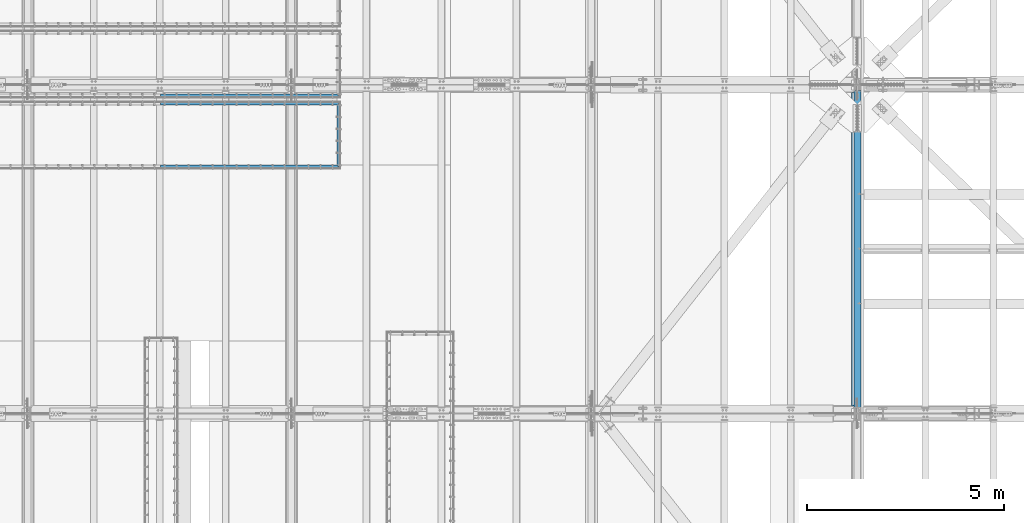
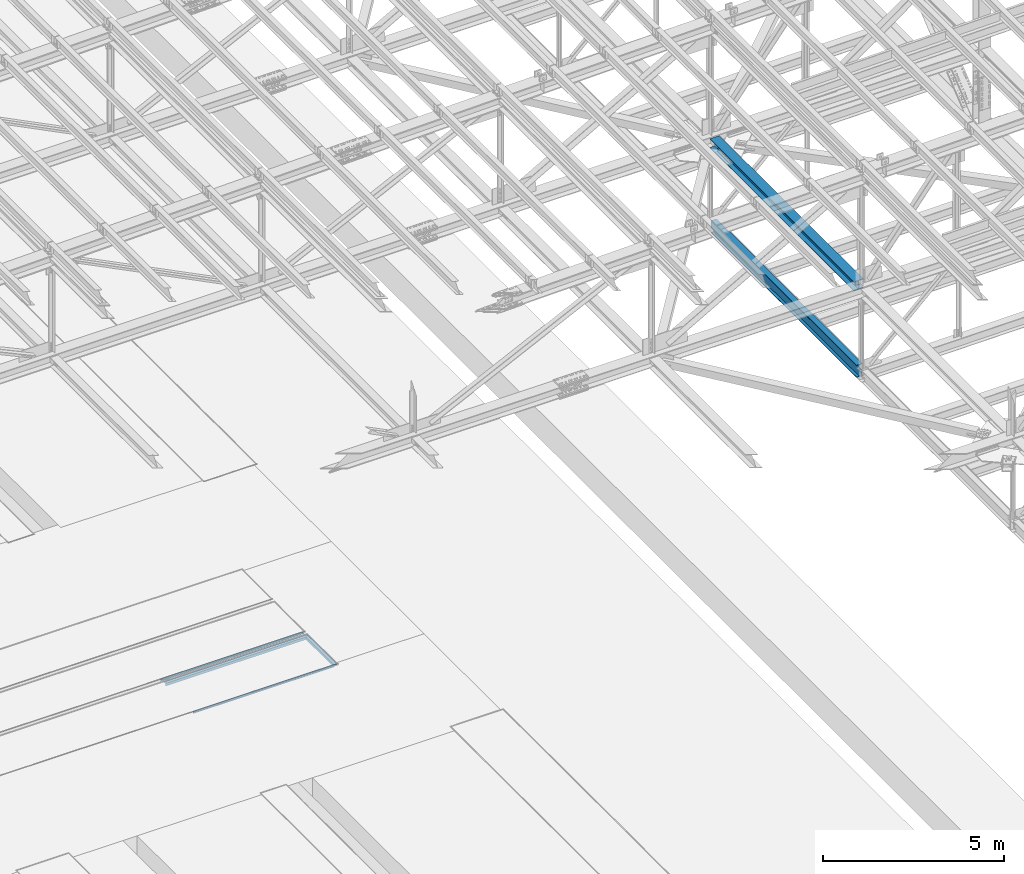
# One storey, part 1857 of 3843: 6 beams, 6 elements without a shape of their own.
"""IFC2X3 building model written with IfcOpenShell, lengths in millimetres."""

from ifc_helpers import new_model, si_unit, frame, origin_with_axes, place, context, subcontext, project, spatial, faceted_brep, material, type_object, element, aggregate, save


model = new_model("IFC2X3")

# Units and contexts
model_context = context("Model", 3, precision=1e-05, world=origin_with_axes())
body_context = subcontext(model_context, "Body", "Model", "MODEL_VIEW")
ifc_project = project(units=[si_unit("LENGTHUNIT", "METRE", prefix="MILLI"), si_unit("AREAUNIT", "SQUARE_METRE"), si_unit("VOLUMEUNIT", "CUBIC_METRE"), si_unit("MASSUNIT", "GRAM", prefix="KILO"), si_unit("TIMEUNIT", "SECOND"), si_unit("PLANEANGLEUNIT", "RADIAN"), si_unit("SOLIDANGLEUNIT", "STERADIAN"), si_unit("THERMODYNAMICTEMPERATUREUNIT", "DEGREE_CELSIUS"), si_unit("LUMINOUSINTENSITYUNIT", "LUMEN")], contexts=[model_context])

# Site, building, storey
site_placement = place(None, origin_with_axes())
site = spatial("IfcSite", under=ifc_project, at=site_placement, CompositionType="ELEMENT")
building_placement = place(site_placement, origin_with_axes())
building = spatial("IfcBuilding", under=site, at=building_placement, Name="Undefined", CompositionType="ELEMENT")
storey_placement = place(building_placement, origin_with_axes())
storey = spatial("IfcBuildingStorey", under=building, at=storey_placement, Name="Undefined", CompositionType="ELEMENT", Elevation=0.0)

# Assembly, beam
assembly_1_placement = place(storey_placement, origin_with_axes())
assembly_1 = element("IfcElementAssembly", 1, at=assembly_1_placement, inside=storey, Name="EMBED_ANGLE", AssemblyPlace="NOTDEFINED", PredefinedType="RIGID_FRAME")
ifc_material_1 = material(Name="STEEL/A36")
beam_type_1 = type_object("IfcBeamType", Name="L3-1/2X3-1/2X5/16", PredefinedType="NOTDEFINED")
beam_1_placement = place(assembly_1_placement, frame((63875.412, 58632.3439999965, 30410.15), z_axis=(0.0, 0.0, -1.0), x_axis=(-1.0, 0.0, 0.0)))
beam_1 = element("IfcBeam", 2, at=beam_1_placement, type_object=beam_type_1, material=ifc_material_1, Name="EMBED_ANGLE", ObjectType="L3-1/2X3-1/2X5/16", context=body_context, shape_type="Brep", body=[
    faceted_brep([(88.8999999971129, 44.4500000000007, -44.4499999999971), (88.8999999965163, 44.4499999999971, 44.4500000000007), (4571.99999999999, 44.4499999999971, 44.4500000000007), (4571.99999999999, 44.4499999999971, -44.4500000000007), (80.9624999965163, 36.5124999999971, 44.4500000000007), (4571.99999999999, 36.5124999999971, 44.4500000000007), (80.9624999971129, 36.5125000000007, -36.5124999999971), (4571.99999999999, 36.5124999999971, -36.5125000000007), (3.63797880709171e-12, -44.4499999999971, -36.5125000000007), (4571.99999999999, -44.4499999999971, -36.5125000000007), (3.63797880709171e-12, -44.4499999999971, -44.4500000000007), (4571.99999999999, -44.4499999999971, -44.4500000000007)], [[[0, 1, 2, 3]], [[1, 4, 5, 2]], [[4, 6, 7, 5]], [[6, 8, 9, 7]], [[8, 10, 11, 9]], [[10, 0, 3, 11]], [[5, 7, 9, 11, 3, 2]], [[10, 8, 6, 4, 1, 0]]]),
])
aggregate(assembly_1, [beam_1])

assembly_2_placement = place(storey_placement, origin_with_axes())
assembly_2 = element("IfcElementAssembly", 3, at=assembly_2_placement, inside=storey, Name="EMBED_ANGLE", AssemblyPlace="NOTDEFINED", PredefinedType="RIGID_FRAME")
beam_2_placement = place(assembly_2_placement, frame((63830.9615883789, 56784.8750000029, 30410.15), z_axis=(1.0, 0.0, 0.0), x_axis=(0.0, 1.0, 0.0)))
beam_2 = element("IfcBeam", 4, at=beam_2_placement, type_object=beam_type_1, material=ifc_material_1, Name="EMBED_ANGLE", ObjectType="L3-1/2X3-1/2X5/16", context=body_context, shape_type="Brep", body=[
    faceted_brep([(88.8999999971129, 44.4500000000007, -44.4499999999971), (-3.63797880709171e-12, 44.4499999999971, 44.4500000000007), (1702.18099999712, 44.4500000000007, 44.4499999999971), (1613.28099999713, 44.4500000000007, -44.4499999999971), (-3.63797880709171e-12, 36.5124999999971, 44.4500000000007), (1702.18099999712, 36.5125000000007, 44.4499999999971), (80.9624999971129, 36.5125000000007, -36.5124999999971), (1621.21849999713, 36.5125000000007, -36.5124999999971), (80.9624999971129, -44.4500000000007, -36.5124999999971), (1621.21849999713, -44.4500000000007, -36.5124999999971), (88.8999999971129, -44.4500000000007, -44.4499999999971), (1613.28099999713, -44.4500000000007, -44.4499999999971)], [[[0, 1, 2, 3]], [[1, 4, 5, 2]], [[4, 6, 7, 5]], [[6, 8, 9, 7]], [[8, 10, 11, 9]], [[10, 0, 3, 11]], [[5, 7, 9, 11, 3, 2]], [[10, 8, 6, 4, 1, 0]]]),
])
aggregate(assembly_2, [beam_2])

assembly_3_placement = place(storey_placement, origin_with_axes())
assembly_3 = element("IfcElementAssembly", 5, at=assembly_3_placement, inside=storey, Name="EMBED_ANGLE", AssemblyPlace="NOTDEFINED", PredefinedType="RIGID_FRAME")
beam_3_placement = place(assembly_3_placement, frame((63875.4115883789, 56829.325, 30410.15), z_axis=(0.0, 0.0, -1.0), x_axis=(-1.0, 0.0, 0.0)))
beam_3 = element("IfcBeam", 6, at=beam_3_placement, type_object=beam_type_1, material=ifc_material_1, Name="EMBED_ANGLE", ObjectType="L3-1/2X3-1/2X5/16", context=body_context, shape_type="Brep", body=[
    faceted_brep([(88.8999999971129, 44.4500000000007, -44.4499999999971), (88.8999999965163, 44.4499999999971, 44.4500000000007), (4571.99999999999, 44.4499999999971, 44.4500000000007), (4571.99999999999, 44.4499999999971, -44.4500000000007), (80.9624999965163, 36.5124999999971, 44.4500000000007), (4571.99999999999, 36.5124999999971, 44.4500000000007), (80.9624999971129, 36.5125000000007, -36.5124999999971), (4571.99999999999, 36.5124999999971, -36.5125000000007), (3.63797880709171e-12, -44.4499999999971, -36.5125000000007), (4571.99999999999, -44.4499999999971, -36.5125000000007), (3.63797880709171e-12, -44.4499999999971, -44.4500000000007), (4571.99999999999, -44.4499999999971, -44.4500000000007)], [[[0, 1, 2, 3]], [[1, 4, 5, 2]], [[4, 6, 7, 5]], [[6, 8, 9, 7]], [[8, 10, 11, 9]], [[10, 0, 3, 11]], [[5, 7, 9, 11, 3, 2]], [[10, 8, 6, 4, 1, 0]]]),
])
aggregate(assembly_3, [beam_3])

assembly_4_placement = place(storey_placement, origin_with_axes())
assembly_4 = element("IfcElementAssembly", 7, at=assembly_4_placement, inside=storey, Name="EMBED_ANGLE", AssemblyPlace="NOTDEFINED", PredefinedType="RIGID_FRAME")
beam_4_placement = place(assembly_4_placement, frame((59303.4115883789, 58442.606, 30410.15), z_axis=(0.0, 0.0, -1.0), x_axis=(1.0, 0.0, 0.0)))
beam_4 = element("IfcBeam", 8, at=beam_4_placement, type_object=beam_type_1, material=ifc_material_1, Name="EMBED_ANGLE", ObjectType="L3-1/2X3-1/2X5/16", context=body_context, shape_type="Brep", body=[
    faceted_brep([(-3.63797880709171e-12, 44.4499999999971, -44.4500000000007), (-3.63797880709171e-12, 44.4499999999971, 44.4500000000007), (4483.09999999999, 44.4499999999971, 44.4500000000007), (4483.09999999999, 44.4499999999971, -44.4500000000007), (-3.63797880709171e-12, 36.5124999999971, 44.4500000000007), (4491.03749999999, 36.5124999999971, 44.4500000000007), (-3.63797880709171e-12, 36.5124999999971, -36.5125000000007), (4491.03749999999, 36.5124999999971, -36.5125000000007), (3.63797880709171e-12, -44.4499999999971, -36.5125000000007), (4571.99999999999, -44.4499999999971, -36.5125000000007), (3.63797880709171e-12, -44.4499999999971, -44.4500000000007), (4571.99999999999, -44.4499999999971, -44.4500000000007)], [[[0, 1, 2, 3]], [[1, 4, 5, 2]], [[4, 6, 7, 5]], [[6, 8, 9, 7]], [[8, 10, 11, 9]], [[10, 0, 3, 11]], [[5, 7, 9, 11, 3, 2]], [[10, 8, 6, 4, 1, 0]]]),
])
aggregate(assembly_4, [beam_4])

assembly_5_placement = place(storey_placement, origin_with_axes())
assembly_5 = element("IfcElementAssembly", 9, at=assembly_5_placement, inside=storey, Name="BEAM", AssemblyPlace="NOTDEFINED", PredefinedType="RIGID_FRAME")
ifc_material_2 = material(Name="STEEL/A992")
beam_type_2 = type_object("IfcBeamType", Name="W12X65", PredefinedType="NOTDEFINED")
beam_5_placement = place(assembly_5_placement, frame((77012.8, 50558.7, 42337.7632586077), z_axis=(0.0, -0.000574734999907376, 0.999999834839826), x_axis=(0.0, 0.999999834839826, 0.000574734999904049)))
beam_5 = element("IfcBeam", 10, at=beam_5_placement, type_object=beam_type_2, material=ifc_material_2, Name="BEAM", ObjectType="W12X65", context=body_context, shape_type="Brep", body=[
    faceted_brep([(198.349027743439, 152.399999999994, -153.987500000367), (198.358151663073, 152.399999999994, -138.112500000309), (8158.0844693554, 152.399999999994, -138.112499995172), (8158.07534543578, 152.399999999994, -153.98749999523), (198.358151663073, 4.76249999999709, -138.112500000309), (8158.0844693554, 4.76249999999709, -138.112499995172), (198.516907864643, 4.76249999999709, 138.11250000057), (8158.24322555697, 4.76249999999709, 138.112500005707), (198.516907864643, 152.399999999994, 138.11250000057), (8158.24322555697, 152.399999999994, 138.112500005707), (198.526031784277, 152.399999999994, 153.987500000629), (8158.25234947661, 152.399999999994, 153.987500005765), (198.526031784277, -152.399999999994, 153.987500000629), (8158.25234947661, -152.399999999994, 153.987500005765), (198.516907864643, -152.399999999994, 138.11250000057), (8158.24322555697, -152.399999999994, 138.112500005707), (198.516907864643, -4.76249999999709, 138.11250000057), (8158.24322555697, -4.76249999999709, 138.112500005707), (198.358151663073, -4.76249999999709, -138.112500000309), (8158.0844693554, -4.76249999999709, -138.112499995172), (198.358151663073, -152.399999999994, -138.112500000309), (8158.0844693554, -152.399999999994, -138.112499995172), (198.349027743439, -152.399999999994, -153.987500000367), (8158.07534543578, -152.399999999994, -153.98749999523)], [[[0, 1, 2, 3]], [[1, 4, 5, 2]], [[4, 6, 7, 5]], [[6, 8, 9, 7]], [[8, 10, 11, 9]], [[10, 12, 13, 11]], [[12, 14, 15, 13]], [[14, 16, 17, 15]], [[16, 18, 19, 17]], [[18, 20, 21, 19]], [[20, 22, 23, 21]], [[22, 0, 3, 23]], [[5, 7, 9, 11, 13, 15, 17, 19, 21, 23, 3, 2]], [[22, 20, 18, 16, 14, 12, 10, 8, 6, 4, 1, 0]]]),
])
aggregate(assembly_5, [beam_5])

assembly_6_placement = place(storey_placement, origin_with_axes())
assembly_6 = element("IfcElementAssembly", 11, at=assembly_6_placement, inside=storey, Name="BEAM", AssemblyPlace="NOTDEFINED", PredefinedType="RIGID_FRAME")
beam_type_3 = type_object("IfcBeamType", Name="W16X57", PredefinedType="NOTDEFINED")
beam_6_placement = place(assembly_6_placement, frame((77012.8, 50558.7, 39476.3625), z_axis=(0.0, 0.0, 1.0), x_axis=(0.0, 1.0, 0.0)))
beam_6 = element("IfcBeam", 12, at=beam_6_placement, type_object=beam_type_3, material=ifc_material_2, Name="BEAM", ObjectType="W16X57", context=body_context, shape_type="Brep", body=[
    faceted_brep([(8204.99375000002, -5.55624999999418, -190.5), (8204.99375000002, -90.4875000000029, -190.5), (8204.99375000002, -90.4875000000029, -207.962500000001), (8204.99375000002, 90.4875000000029, -207.962500000001), (8204.99375000002, 90.4875000000029, -190.5), (8204.99375000002, 5.55624999999418, -190.5), (8204.99375000002, 5.55624999999418, -170.122499798672), (8204.99375000002, -5.55624999999418, -170.122499798672), (8205.96047992261, 5.55624999999418, -165.262420280626), (8205.96047992261, -5.55624999999418, -165.262420280626), (8208.71349382309, 5.55624999999418, -161.142243812472), (8208.71349382309, -5.55624999999418, -161.142243812472), (8212.83367029125, 5.55624999999418, -158.389229911998), (8212.83367029125, -5.55624999999418, -158.389229911998), (8217.69374980929, 5.55624999999418, -157.422499989407), (8217.69374980929, -5.55624999999418, -157.422499989407), (8338.34375000003, -5.55624999999418, -157.422499989407), (8338.34375000003, 5.55624999999418, -157.422499989407), (151.606250000026, 5.55624999999418, 190.5), (151.606250000026, 90.4875000000029, 190.5), (8204.99375000002, 90.4875000000029, 190.5), (8204.99375000002, 5.55624999999418, 190.5), (151.606250000026, -5.55624999999418, -170.122499798665), (151.606250000026, 5.55624999999418, -170.122499798665), (151.606250000026, 5.55624999999418, -190.5), (151.606250000026, 90.4875000000029, -190.5), (151.606250000026, 90.4875000000029, -207.962500000001), (151.606250000026, -90.4875000000029, -207.962500000001), (151.606250000026, -90.4875000000029, -190.5), (151.606250000026, -5.55624999999418, -190.5), (150.639520077442, -5.55624999999418, -165.262420280618), (150.639520077442, 5.55624999999418, -165.262420280618), (147.886506176961, -5.55624999999418, -161.142243812465), (147.886506176961, 5.55624999999418, -161.142243812465), (143.7663297088, -5.55624999999418, -158.389229911991), (143.7663297088, 5.55624999999418, -158.389229911991), (138.906250190761, -5.55624999999418, -157.4224999894), (138.906250190761, 5.55624999999418, -157.4224999894), (18.2562499999913, -5.55624999999418, -157.4224999894), (18.2562499999913, 5.55624999999418, -157.4224999894), (18.2562499999913, -5.55624999999418, 106.102500010602), (18.2562499999913, 5.55624999999418, 106.102500010602), (138.906250190761, -5.55624999999418, 106.102500010602), (138.906250190761, 5.55624999999418, 106.102500010602), (143.7663297088, -5.55624999999418, 107.069229933193), (143.7663297088, 5.55624999999418, 107.069229933193), (147.886506176961, -5.55624999999418, 109.822243833667), (147.886506176961, 5.55624999999418, 109.822243833667), (150.639520077442, -5.55624999999418, 113.942420301821), (150.639520077442, 5.55624999999418, 113.942420301821), (151.606250000026, -5.55624999999418, 118.802499819867), (151.606250000026, 5.55624999999418, 118.802499819867), (151.606250000026, -90.4875000000029, 207.962500000001), (151.606250000026, 90.4875000000029, 207.962500000001), (151.606250000026, -5.55624999999418, 190.5), (151.606250000026, -90.4875000000029, 190.5), (8204.99375000002, -5.55624999999418, 190.5), (8204.99375000002, -90.4875000000029, 190.5), (8204.99375000002, -90.4875000000029, 207.962500000001), (8204.99375000002, 90.4875000000029, 207.962500000001), (8204.99375000002, -5.55624999999418, 118.80249981986), (8204.99375000002, 5.55624999999418, 118.80249981986), (8205.96047992261, -5.55624999999418, 113.942420301813), (8205.96047992261, 5.55624999999418, 113.942420301813), (8208.71349382309, -5.55624999999418, 109.82224383366), (8208.71349382309, 5.55624999999418, 109.82224383366), (8212.83367029125, -5.55624999999418, 107.069229933186), (8212.83367029125, 5.55624999999418, 107.069229933186), (8217.69374980929, -5.55624999999418, 106.102500010595), (8217.69374980929, 5.55624999999418, 106.102500010595), (8338.34375000003, -5.55624999999418, 106.102500010595), (8338.34375000003, 5.55624999999418, 106.102500010595)], [[[0, 1, 2, 3, 4, 5, 6, 7]], [[7, 6, 8, 9]], [[9, 8, 10, 11]], [[11, 10, 12, 13]], [[13, 12, 14, 15]], [[16, 15, 14, 17]], [[18, 19, 20, 21]], [[22, 23, 24, 25, 26, 27, 28, 29]], [[30, 31, 23, 22]], [[32, 33, 31, 30]], [[34, 35, 33, 32]], [[36, 37, 35, 34]], [[38, 39, 37, 36]], [[40, 41, 39, 38]], [[42, 43, 41, 40]], [[44, 45, 43, 42]], [[46, 47, 45, 44]], [[48, 49, 47, 46]], [[50, 51, 49, 48]], [[52, 53, 19, 18, 51, 50, 54, 55]], [[55, 54, 56, 57]], [[52, 55, 57, 58]], [[53, 52, 58, 59]], [[19, 53, 59, 20]], [[58, 57, 56, 60, 61, 21, 20, 59]], [[62, 63, 61, 60]], [[64, 65, 63, 62]], [[66, 67, 65, 64]], [[68, 69, 67, 66]], [[70, 71, 69, 68]], [[71, 70, 16, 17]], [[12, 10, 8, 6, 5, 24, 23, 31, 33, 35, 37, 39, 41, 43, 45, 47, 49, 51, 18, 21, 61, 63, 65, 67, 69, 71, 17, 14]], [[25, 24, 5, 4]], [[26, 25, 4, 3]], [[27, 26, 3, 2]], [[28, 27, 2, 1]], [[29, 28, 1, 0]], [[70, 68, 66, 64, 62, 60, 56, 54, 50, 48, 46, 44, 42, 40, 38, 36, 34, 32, 30, 22, 29, 0, 7, 9, 11, 13, 15, 16]]]),
])
aggregate(assembly_6, [beam_6])

save(model, "model.ifc")
